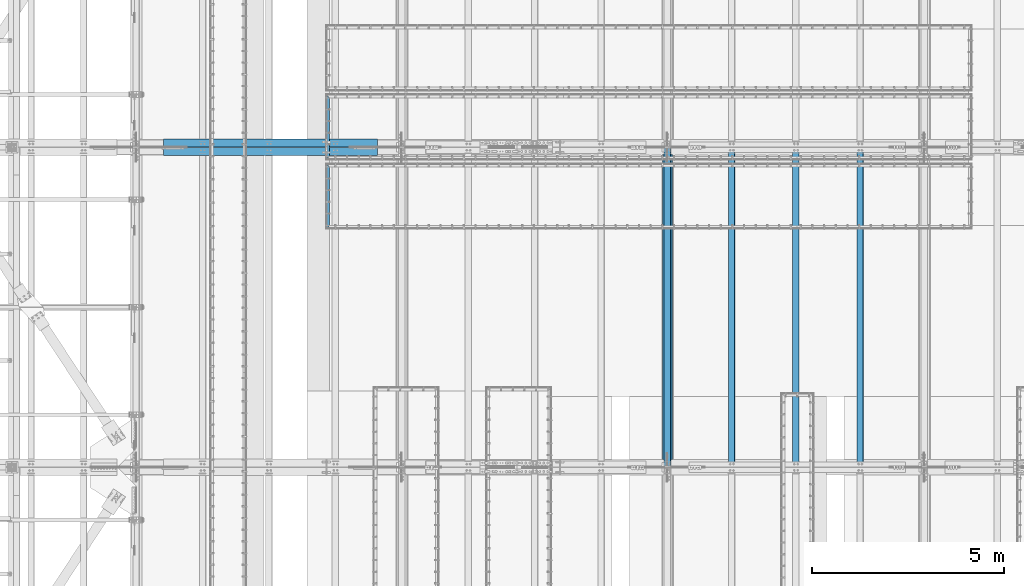
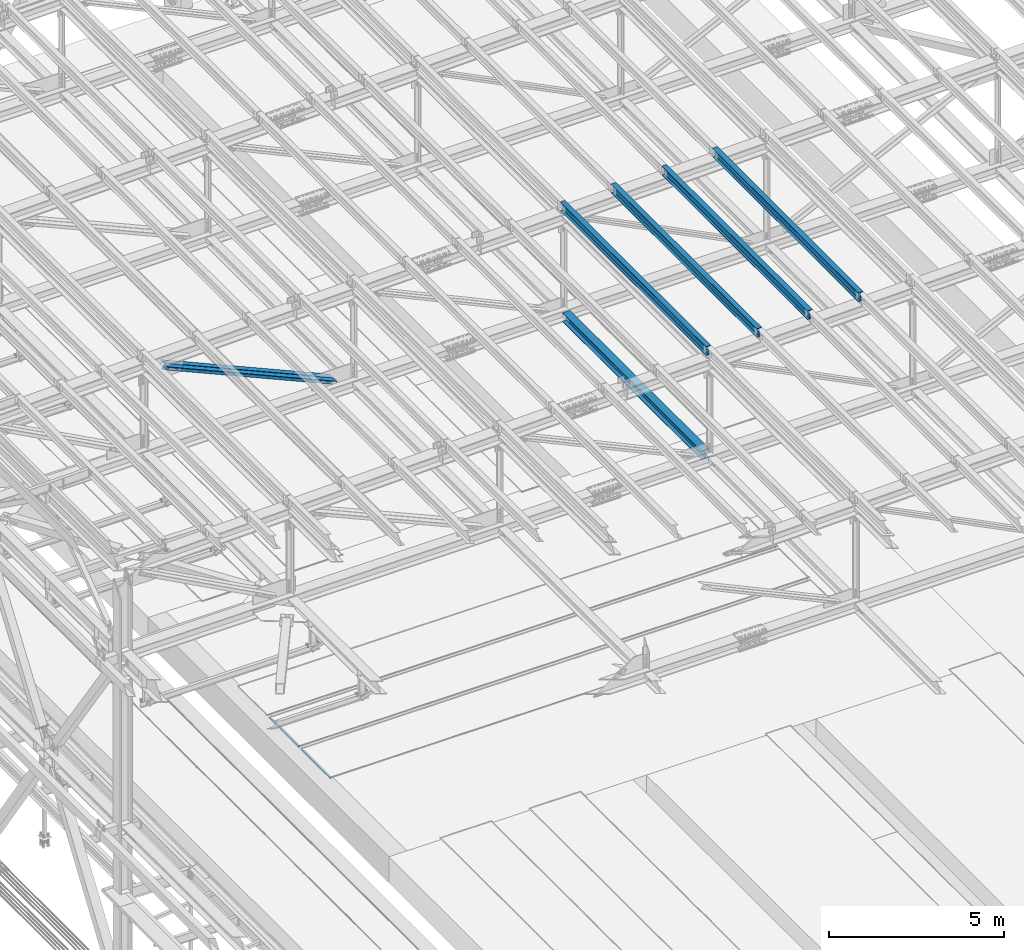
# One storey, part 1847 of 3843: 7 beams, 2 members, 9 elements without a shape of their own.
"""IFC2X3 building model written with IfcOpenShell, lengths in millimetres."""

from ifc_helpers import new_model, si_unit, frame, origin_with_axes, place, context, subcontext, project, spatial, faceted_brep, material, type_object, element, aggregate, save


model = new_model("IFC2X3")

# Units and contexts
model_context = context("Model", 3, precision=1e-05, world=origin_with_axes())
body_context = subcontext(model_context, "Body", "Model", "MODEL_VIEW")
ifc_project = project(units=[si_unit("LENGTHUNIT", "METRE", prefix="MILLI"), si_unit("AREAUNIT", "SQUARE_METRE"), si_unit("VOLUMEUNIT", "CUBIC_METRE"), si_unit("MASSUNIT", "GRAM", prefix="KILO"), si_unit("TIMEUNIT", "SECOND"), si_unit("PLANEANGLEUNIT", "RADIAN"), si_unit("SOLIDANGLEUNIT", "STERADIAN"), si_unit("THERMODYNAMICTEMPERATUREUNIT", "DEGREE_CELSIUS"), si_unit("LUMINOUSINTENSITYUNIT", "LUMEN")], contexts=[model_context])

# Site, building, storey
site_placement = place(None, origin_with_axes())
site = spatial("IfcSite", under=ifc_project, at=site_placement, CompositionType="ELEMENT")
building_placement = place(site_placement, origin_with_axes())
building = spatial("IfcBuilding", under=site, at=building_placement, Name="Undefined", CompositionType="ELEMENT")
storey_placement = place(building_placement, origin_with_axes())
storey = spatial("IfcBuildingStorey", under=building, at=storey_placement, Name="Undefined", CompositionType="ELEMENT", Elevation=0.0)

# Assembly, beam
assembly_1_placement = place(storey_placement, origin_with_axes())
assembly_1 = element("IfcElementAssembly", 1, at=assembly_1_placement, inside=storey, Name="EMBED_ANGLE", AssemblyPlace="NOTDEFINED", PredefinedType="RIGID_FRAME")
ifc_material_1 = material(Name="STEEL/A36")
beam_type_1 = type_object("IfcBeamType", Name="L3-1/2X3-1/2X5/16", PredefinedType="NOTDEFINED")
beam_1_placement = place(assembly_1_placement, frame((47066.962390625, 58587.894, 30410.15), z_axis=(0.0, 0.0, -1.0), x_axis=(0.0, 1.0, 0.0)))
beam_1 = element("IfcBeam", 2, at=beam_1_placement, type_object=beam_type_1, material=ifc_material_1, Name="EMBED_ANGLE", ObjectType="L3-1/2X3-1/2X5/16", context=body_context, shape_type="Brep", body=[
    faceted_brep([(88.8999999971129, 44.4500000000007, -44.4499999999971), (88.8999999965163, 44.4499999999971, 44.4500000000007), (1613.28099999655, 44.4499999999971, 44.4500000000007), (1613.28099999713, 44.4500000000007, -44.4499999999971), (80.9624999965163, 36.5124999999971, 44.4500000000007), (1621.21849999655, 36.5124999999971, 44.4500000000007), (80.9624999971129, 36.5125000000007, -36.5124999999971), (1621.21849999713, 36.5125000000007, -36.5124999999971), (3.63797880709171e-12, -44.4499999999971, -36.5125000000007), (1702.18099999654, -44.4499999999971, -36.5125000000007), (3.63797880709171e-12, -44.4499999999971, -44.4500000000007), (1702.18099999654, -44.4499999999971, -44.4500000000007)], [[[0, 1, 2, 3]], [[1, 4, 5, 2]], [[4, 6, 7, 5]], [[6, 8, 9, 7]], [[8, 10, 11, 9]], [[10, 0, 3, 11]], [[5, 7, 9, 11, 3, 2]], [[10, 8, 6, 4, 1, 0]]]),
])
aggregate(assembly_1, [beam_1])

assembly_2_placement = place(storey_placement, origin_with_axes())
assembly_2 = element("IfcElementAssembly", 3, at=assembly_2_placement, inside=storey, Name="EMBED_ANGLE", AssemblyPlace="NOTDEFINED", PredefinedType="RIGID_FRAME")
beam_2_placement = place(assembly_2_placement, frame((47066.9619790039, 56784.8750000035, 30410.15), z_axis=(0.0, 0.0, -1.0), x_axis=(0.0, 1.0, 0.0)))
beam_2 = element("IfcBeam", 4, at=beam_2_placement, type_object=beam_type_1, material=ifc_material_1, Name="EMBED_ANGLE", ObjectType="L3-1/2X3-1/2X5/16", context=body_context, shape_type="Brep", body=[
    faceted_brep([(88.8999999971129, 44.4500000000007, -44.4499999999971), (88.8999999965163, 44.4499999999971, 44.4500000000007), (1613.28099999655, 44.4499999999971, 44.4500000000007), (1613.28099999713, 44.4500000000007, -44.4499999999971), (80.9624999965163, 36.5124999999971, 44.4500000000007), (1621.21849999655, 36.5124999999971, 44.4500000000007), (80.9624999971129, 36.5125000000007, -36.5124999999971), (1621.21849999713, 36.5125000000007, -36.5124999999971), (3.63797880709171e-12, -44.4499999999971, -36.5125000000007), (1702.18099999654, -44.4499999999971, -36.5125000000007), (3.63797880709171e-12, -44.4499999999971, -44.4500000000007), (1702.18099999654, -44.4499999999971, -44.4500000000007)], [[[0, 1, 2, 3]], [[1, 4, 5, 2]], [[4, 6, 7, 5]], [[6, 8, 9, 7]], [[8, 10, 11, 9]], [[10, 0, 3, 11]], [[5, 7, 9, 11, 3, 2]], [[10, 8, 6, 4, 1, 0]]]),
])
aggregate(assembly_2, [beam_2])

assembly_3_placement = place(storey_placement, origin_with_axes())
assembly_3 = element("IfcElementAssembly", 5, at=assembly_3_placement, inside=storey, Name="BEAM", AssemblyPlace="NOTDEFINED", PredefinedType="RIGID_FRAME")
ifc_material_2 = material(Name="STEEL/A992")
beam_type_2 = type_object("IfcBeamType", Name="W12X26", PredefinedType="NOTDEFINED")
beam_3_placement = place(assembly_3_placement, frame((55927.5092622662, 50558.6570480581, 46065.959605115), z_axis=(-0.0211520978139451, -0.000276085000063176, 0.99977623123134), x_axis=(0.0, 0.999999961871417, 0.000276146999964482)))
beam_3 = element("IfcBeam", 6, at=beam_3_placement, type_object=beam_type_2, material=ifc_material_2, Name="BEAM", ObjectType="W12X26", context=body_context, shape_type="Brep", body=[
    faceted_brep([(12.6995182858154, 82.5499999993117, -155.575000000114), (12.7021479976538, 82.5499999993481, -146.050000000119), (8343.90246569729, 82.5499999989333, -146.049999980707), (8343.89983598545, 82.549999998897, -155.574999980701), (12.7026116341149, 3.17499999947177, -146.04999999993), (8343.90292933375, 3.17499999906431, -146.049999980511), (12.7832561306204, 3.17500000049768, 146.049999999981), (8343.98357383026, 3.17500000009022, 146.050000019393), (12.7827924941594, 82.5500000003667, 146.049999999792), (8343.9831101938, 82.5499999999593, 146.050000019211), (12.785422206005, 82.5500000004031, 155.574999999793), (8343.98573990564, 82.5499999999956, 155.575000019213), (12.7863865698382, -82.5499999993262, 155.575000000194), (8343.98670426948, -82.5499999997337, 155.575000019606), (12.7837568579926, -82.5499999993554, 146.050000000192), (8343.98407455764, -82.5499999997628, 146.050000019612), (12.7832932215388, -3.17499999949359, 146.050000000003), (8343.98361092118, -3.17499999990105, 146.050000019415), (12.7026487250259, -3.1750000005195, -146.049999999908), (8343.90296642467, -3.17500000092696, -146.049999980496), (12.703112361487, -82.5500000003813, -146.049999999719), (8343.90343006112, -82.550000000796, -146.049999980307), (12.7004826496413, -82.5500000004176, -155.574999999721), (8343.90080034929, -82.5500000008251, -155.574999980301)], [[[0, 1, 2, 3]], [[1, 4, 5, 2]], [[4, 6, 7, 5]], [[6, 8, 9, 7]], [[8, 10, 11, 9]], [[10, 12, 13, 11]], [[12, 14, 15, 13]], [[14, 16, 17, 15]], [[16, 18, 19, 17]], [[18, 20, 21, 19]], [[20, 22, 23, 21]], [[22, 0, 3, 23]], [[5, 7, 9, 11, 13, 15, 17, 19, 21, 23, 3, 2]], [[22, 20, 18, 16, 14, 12, 10, 8, 6, 4, 1, 0]]]),
])
aggregate(assembly_3, [beam_3])

assembly_4_placement = place(storey_placement, origin_with_axes())
assembly_4 = element("IfcElementAssembly", 7, at=assembly_4_placement, inside=storey, Name="BEAM", AssemblyPlace="NOTDEFINED", PredefinedType="RIGID_FRAME")
beam_4_placement = place(assembly_4_placement, frame((60956.709262328, 50558.6459138303, 46182.1124380621), z_axis=(-0.0211520982859365, -0.000347652999960701, 0.999776208896518), x_axis=(0.0, 0.999999939541574, 0.000347730999840218)))
beam_4 = element("IfcBeam", 8, at=beam_4_placement, type_object=beam_type_2, material=ifc_material_2, Name="BEAM", ObjectType="W12X26", context=body_context, shape_type="Brep", body=[
    faceted_brep([(12.6993519677417, 82.5499999996464, -155.575000000448), (12.7027050122924, 82.549999999399, -146.05000000033), (8343.90320874514, 82.5499999990207, -146.049999982635), (8343.89989734816, 82.5499999989916, -155.574999982651), (12.7032888342437, 3.17499999954453, -146.050000000228), (8343.90379256709, 3.17499999916618, -146.049999982519), (12.8048383416972, 3.17500000044674, 146.050000000287), (8344.00534207455, 3.17500000006839, 146.050000017989), (12.8042545197532, 82.5500000002939, 146.050000000178), (8344.00475825262, 82.5499999999156, 146.050000017873), (12.8075659167298, 82.5500000003231, 155.575000000194), (8344.00806964959, 82.5499999999447, 155.575000017889), (12.8087802663867, -82.5499999993699, 155.575000000426), (8344.00928399924, -82.5499999997483, 155.575000018129), (12.8054688694028, -82.5499999994063, 146.050000000403), (8344.00597260227, -82.5499999997846, 146.050000018105), (12.8048850474515, -3.1749999995518, 146.050000000301), (8344.00538878032, -3.17499999993015, 146.050000017996), (12.7033355399981, -3.17500000044674, -146.050000000214), (8343.90383927285, -3.17500000082509, -146.049999982519), (12.7039193619421, -82.5500000002939, -146.050000000105), (8343.9044230948, -82.5500000006723, -146.049999982402), (12.7006496460817, -82.5500000000829, -155.57500000055), (8343.90111169781, -82.5500000007087, -155.574999982418)], [[[0, 1, 2, 3]], [[1, 4, 5, 2]], [[4, 6, 7, 5]], [[6, 8, 9, 7]], [[8, 10, 11, 9]], [[10, 12, 13, 11]], [[12, 14, 15, 13]], [[14, 16, 17, 15]], [[16, 18, 19, 17]], [[18, 20, 21, 19]], [[20, 22, 23, 21]], [[22, 0, 3, 23]], [[5, 7, 9, 11, 13, 15, 17, 19, 21, 23, 3, 2]], [[22, 20, 18, 16, 14, 12, 10, 8, 6, 4, 1, 0]]]),
])
aggregate(assembly_4, [beam_4])

assembly_5_placement = place(storey_placement, origin_with_axes())
assembly_5 = element("IfcElementAssembly", 9, at=assembly_5_placement, inside=storey, Name="BEAM", AssemblyPlace="NOTDEFINED", PredefinedType="RIGID_FRAME")
beam_5_placement = place(assembly_5_placement, frame((59280.3092623045, 50558.6469923113, 46143.9151995265), z_axis=(-0.0211520982357469, -0.000340721000095072, 0.999776211284018), x_axis=(0.0, 0.999999941928701, 0.000340796999975329)))
beam_5 = element("IfcBeam", 10, at=beam_5_placement, type_object=beam_type_2, material=ifc_material_2, Name="BEAM", ObjectType="W12X26", context=body_context, shape_type="Brep", body=[
    faceted_brep([(12.6994057280026, 82.5499999995227, -155.575000000361), (12.7026510933501, 82.5499999995445, -146.050000000345), (8343.90313492835, 82.5499999995809, -146.050000001749), (8343.89989734816, 82.5499999989916, -155.574999982651), (12.7032232734709, 3.17499999966822, -146.050000000279), (8343.90370710847, 3.1749999997046, -146.050000001676), (12.8027478107033, 3.1750000003085, 146.050000000265), (8344.00323164571, 3.17500000034488, 146.049999998861), (12.8021756305679, 82.5500000001703, 146.050000000185), (8344.00265946557, 82.5500000002066, 146.049999998788), (12.8054209959155, 82.5500000001921, 155.575000000194), (8344.00590483093, 82.5500000002285, 155.574999998804), (12.8066111305816, -82.54999999953, 155.575000000354), (8344.00709496559, -82.5499999995009, 155.574999998964), (12.8033657652413, -82.5499999995518, 146.050000000345), (8344.00384960025, -82.5499999995227, 146.049999998941), (12.8027935851132, -3.17499999967549, 146.050000000265), (8344.00327742012, -3.17499999964639, 146.049999998868), (12.7032690478809, -3.17500000031578, -146.050000000265), (8343.90375288288, -3.17500000028667, -146.050000001662), (12.7038412280162, -82.5500000001775, -146.050000000192), (8343.90432506302, -82.5500000001484, -146.050000001596), (12.7005958626687, -82.5500000002066, -155.575000000215), (8343.90111169781, -82.5500000007087, -155.574999982418)], [[[0, 1, 2, 3]], [[1, 4, 5, 2]], [[4, 6, 7, 5]], [[6, 8, 9, 7]], [[8, 10, 11, 9]], [[10, 12, 13, 11]], [[12, 14, 15, 13]], [[14, 16, 17, 15]], [[16, 18, 19, 17]], [[18, 20, 21, 19]], [[20, 22, 23, 21]], [[22, 0, 3, 23]], [[5, 7, 9, 11, 13, 15, 17, 19, 21, 23, 3, 2]], [[22, 20, 18, 16, 14, 12, 10, 8, 6, 4, 1, 0]]]),
])
aggregate(assembly_5, [beam_5])

assembly_6_placement = place(storey_placement, origin_with_axes())
assembly_6 = element("IfcElementAssembly", 11, at=assembly_6_placement, inside=storey, Name="BEAM", AssemblyPlace="NOTDEFINED", PredefinedType="RIGID_FRAME")
beam_6_placement = place(assembly_6_placement, frame((57603.9092622933, 50558.6525884156, 46105.1975957398), z_axis=(-0.0211520979898778, -0.000304750999974203, 0.999776222900632), x_axis=(-9.99999641329346e-10, 0.999999953542688, 0.000304818999860229)))
beam_6 = element("IfcBeam", 12, at=beam_6_placement, type_object=beam_type_2, material=ifc_material_2, Name="BEAM", ObjectType="W12X26", context=body_context, shape_type="Brep", body=[
    faceted_brep([(12.6995182858154, 82.5499999993117, -155.575000000114), (12.7023711530419, 82.5499999993626, -146.050000000709), (8343.90271783868, 82.5500000001048, -146.049999994), (8343.89983598545, 82.549999998897, -155.574999980701), (12.7028828489565, 3.17499999950815, -146.050000000447), (8343.90326989951, 3.17499997333653, -146.050000021562), (12.791900568518, 3.17500000040309, 146.050000000352), (8343.99228761908, 3.17499997423874, 146.04999997923), (12.7913888726107, 82.5500000002721, 146.05000000009), (8343.99177592317, 82.5499999740932, 146.049999978975), (12.794291624341, 82.5500000002939, 155.575000000106), (8343.9946786749, 82.5499999741296, 155.574999978991), (12.7953559518355, -82.5499999994136, 155.575000000652), (8343.9957430024, -82.5500000255779, 155.574999979537), (12.7924532001052, -82.5499999994427, 146.050000000629), (8343.99284025066, -82.5500000255997, 146.049999979507), (12.7919415041979, -3.17499999958818, 146.050000000367), (8343.99232855476, -3.17500002574525, 146.049999979245), (12.7029237846291, -3.17500000048312, -146.050000000425), (8343.90331083519, -3.17500002665474, -146.05000002154), (12.7034354805437, -82.5500000003449, -146.050000000156), (8343.9038225311, -82.5500000265092, -146.050000021285), (12.7005327288134, -82.5500000003667, -155.575000000194), (8343.90091977938, -82.5500000265383, -155.575000021308)], [[[0, 1, 2, 3]], [[1, 4, 5, 2]], [[4, 6, 7, 5]], [[6, 8, 9, 7]], [[8, 10, 11, 9]], [[10, 12, 13, 11]], [[12, 14, 15, 13]], [[14, 16, 17, 15]], [[16, 18, 19, 17]], [[18, 20, 21, 19]], [[20, 22, 23, 21]], [[22, 0, 3, 23]], [[5, 7, 9, 11, 13, 15, 17, 19, 21, 23, 3, 2]], [[22, 20, 18, 16, 14, 12, 10, 8, 6, 4, 1, 0]]]),
])
aggregate(assembly_6, [beam_6])

# Assembly, member
assembly_7_placement = place(storey_placement, origin_with_axes())
assembly_7 = element("IfcElementAssembly", 13, at=assembly_7_placement, inside=storey, Name="ANGLE", AssemblyPlace="NOTDEFINED", PredefinedType="RIGID_FRAME")
ifc_material_3 = material(Name="STEEL/A572-50")
member_type = type_object("IfcMemberType", Name="L8X8X1/2", PredefinedType="NOTDEFINED")
member_1_placement = place(assembly_7_placement, frame((42062.4, 59026.425, 45368.7993947873), z_axis=(-0.403686943050371, 0.0, -0.914897181114166), x_axis=(0.914897181114165, 0.0, -0.403686943050372)))
member_1 = element("IfcMember", 14, at=member_1_placement, type_object=member_type, material=ifc_material_3, Name="ANGLE", ObjectType="L8X8X1/2", context=body_context, shape_type="Brep", body=[
    faceted_brep([(737.971552119488, 101.599999999999, -101.600000001243), (737.971552119478, 101.599999999999, 101.599999998914), (6838.28532424971, 101.599999999999, 101.599999989317), (6838.28532424971, 101.599999999999, -101.600000010847), (737.971552119478, 88.9000000000015, 101.599999998914), (6838.28532424971, 88.9000000000015, 101.599999989317), (737.971552119478, 88.9000000000015, -88.9000000012311), (6838.28532424971, 88.9000000000015, -88.9000000108354), (737.971552119478, -101.599999999999, -88.9000000012311), (6838.28532424971, -101.599999999999, -88.9000000108354), (737.971552119488, -101.599999999999, -101.600000001243), (6838.28532424971, -101.599999999999, -101.600000010847)], [[[0, 1, 2, 3]], [[1, 4, 5, 2]], [[4, 6, 7, 5]], [[6, 8, 9, 7]], [[8, 10, 11, 9]], [[10, 0, 3, 11]], [[5, 7, 9, 11, 3, 2]], [[10, 8, 6, 4, 1, 0]]]),
])
aggregate(assembly_7, [member_1])

assembly_8_placement = place(storey_placement, origin_with_axes())
assembly_8 = element("IfcElementAssembly", 15, at=assembly_8_placement, inside=storey, Name="ANGLE", AssemblyPlace="NOTDEFINED", PredefinedType="RIGID_FRAME")
member_2_placement = place(assembly_8_placement, frame((48996.6000005146, 58804.175, 42309.1703410612), z_axis=(-0.403686943050371, 0.0, -0.914897181114166), x_axis=(-0.914897181114165, 0.0, 0.403686943050373)))
member_2 = element("IfcMember", 16, at=member_2_placement, type_object=member_type, material=ifc_material_3, Name="ANGLE", ObjectType="L8X8X1/2", context=body_context, shape_type="Brep", body=[
    faceted_brep([(740.927009081697, 101.599999999999, -101.599999998907), (740.92700908169, 101.599999999999, 101.60000000125), (6841.24078121193, 101.599999999999, 101.600000010854), (6841.24078121192, 101.599999999999, -101.599999989303), (740.92700908169, 88.9000000000015, 101.60000000125), (6841.24078121193, 88.9000000000015, 101.600000010854), (740.927009081694, 88.9000000000015, -88.8999999989028), (6841.24078121192, 88.9000000000015, -88.8999999892912), (740.927009081694, -101.599999999999, -88.8999999989028), (6841.24078121192, -101.599999999999, -88.8999999892912), (740.927009081697, -101.599999999999, -101.599999998907), (6841.24078121192, -101.599999999999, -101.599999989303)], [[[0, 1, 2, 3]], [[1, 4, 5, 2]], [[4, 6, 7, 5]], [[6, 8, 9, 7]], [[8, 10, 11, 9]], [[10, 0, 3, 11]], [[5, 7, 9, 11, 3, 2]], [[10, 8, 6, 4, 1, 0]]]),
])
aggregate(assembly_8, [member_2])

# Assembly, beam
assembly_9_placement = place(storey_placement, origin_with_axes())
assembly_9 = element("IfcElementAssembly", 17, at=assembly_9_placement, inside=storey, Name="BEAM", AssemblyPlace="NOTDEFINED", PredefinedType="RIGID_FRAME")
beam_type_3 = type_object("IfcBeamType", Name="W12X53", PredefinedType="NOTDEFINED")
beam_7_placement = place(assembly_9_placement, frame((55930.8, 50558.6999999999, 42329.0538125451), z_axis=(0.0, -0.000274475000092935, 0.999999962331736), x_axis=(0.0, 0.999999962331736, 0.000274475000090999)))
beam_7 = element("IfcBeam", 18, at=beam_7_placement, type_object=beam_type_3, material=ifc_material_2, Name="BEAM", ObjectType="W12X53", context=body_context, shape_type="Brep", body=[
    faceted_brep([(198.39567748351, 127.0, -152.399999999754), (198.399599045224, 127.0, -138.112499999748), (8158.12489888431, 127.0, -138.112499986237), (8158.12097732261, 127.0, -152.39999998625), (198.399599045224, 4.76249999999709, -138.112499999748), (8158.12489888431, 4.76249999999709, -138.112499986237), (198.475415904984, 4.76249999999709, 138.112500000425), (8158.20071574407, 4.76249999999709, 138.112500013936), (198.475415904984, 127.0, 138.112500000425), (8158.20071574407, 127.0, 138.112500013936), (198.479337466692, 127.0, 152.400000000438), (8158.20463730578, 127.0, 152.400000013942), (198.479337466692, -127.0, 152.400000000438), (8158.20463730578, -127.0, 152.400000013942), (198.475415904984, -127.0, 138.112500000425), (8158.20071574407, -127.0, 138.112500013936), (198.475415904984, -4.76249999999709, 138.112500000425), (8158.20071574407, -4.76249999999709, 138.112500013936), (198.399599045224, -4.76249999999709, -138.112499999748), (8158.12489888431, -4.76249999999709, -138.112499986237), (198.399599045224, -127.0, -138.112499999748), (8158.12489888431, -127.0, -138.112499986237), (198.39567748351, -127.0, -152.399999999754), (8158.12097732261, -127.0, -152.39999998625)], [[[0, 1, 2, 3]], [[1, 4, 5, 2]], [[4, 6, 7, 5]], [[6, 8, 9, 7]], [[8, 10, 11, 9]], [[10, 12, 13, 11]], [[12, 14, 15, 13]], [[14, 16, 17, 15]], [[16, 18, 19, 17]], [[18, 20, 21, 19]], [[20, 22, 23, 21]], [[22, 0, 3, 23]], [[5, 7, 9, 11, 13, 15, 17, 19, 21, 23, 3, 2]], [[22, 20, 18, 16, 14, 12, 10, 8, 6, 4, 1, 0]]]),
])
aggregate(assembly_9, [beam_7])

save(model, "model.ifc")
